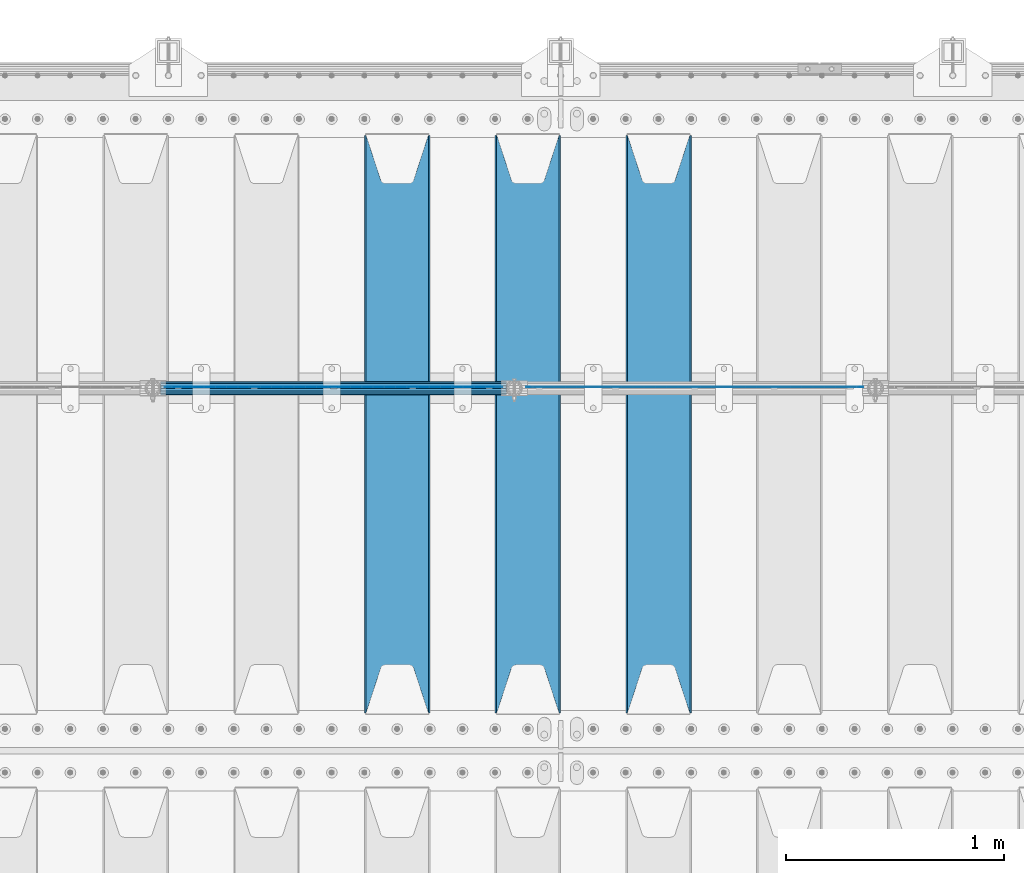
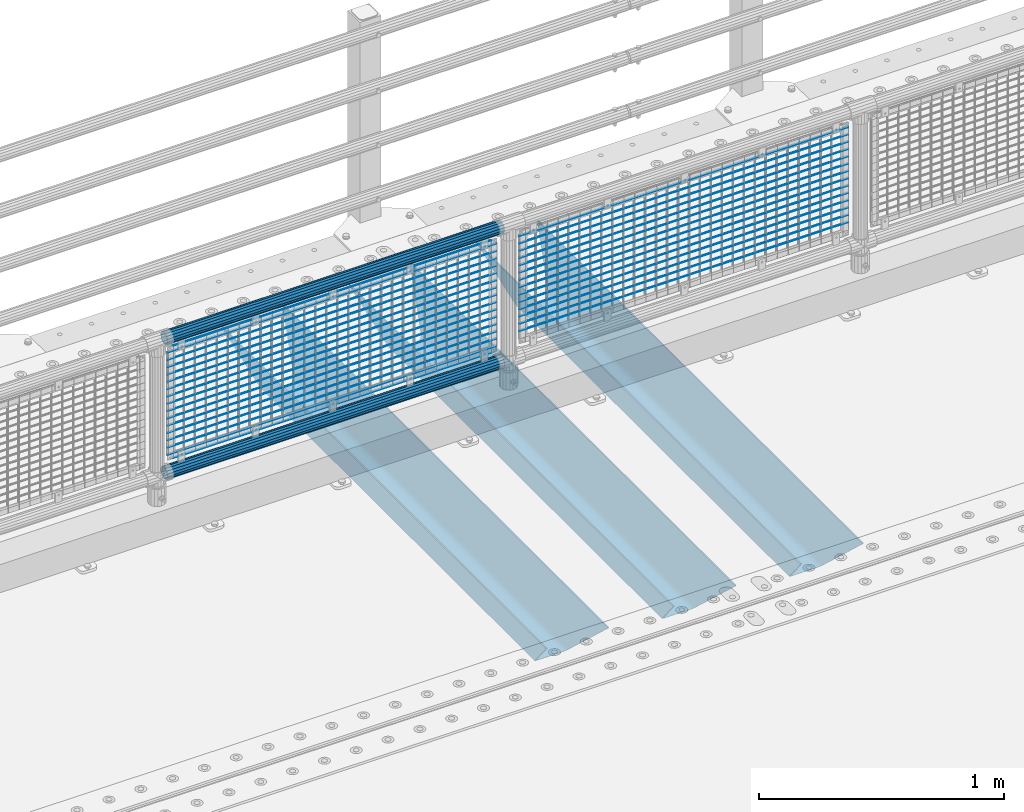
# One storey, part 90 of 193: 36 beams.
"""IFC2X3 building model written with IfcOpenShell, lengths in millimetres."""

from ifc_helpers import new_model, si_unit, frame, origin_with_axes, place, context, subcontext, project, spatial, faceted_brep, material, type_object, element, save


model = new_model("IFC2X3")

# Units and contexts
model_context = context("Model", 3, precision=1e-05, world=origin_with_axes())
body_context = subcontext(model_context, "Body", "Model", "MODEL_VIEW")
ifc_project = project(units=[si_unit("LENGTHUNIT", "METRE", prefix="MILLI"), si_unit("AREAUNIT", "SQUARE_METRE"), si_unit("VOLUMEUNIT", "CUBIC_METRE"), si_unit("MASSUNIT", "GRAM", prefix="KILO"), si_unit("TIMEUNIT", "SECOND"), si_unit("PLANEANGLEUNIT", "RADIAN"), si_unit("SOLIDANGLEUNIT", "STERADIAN"), si_unit("THERMODYNAMICTEMPERATUREUNIT", "DEGREE_CELSIUS"), si_unit("LUMINOUSINTENSITYUNIT", "LUMEN")], contexts=[model_context])

# Site, building, storey
site_placement = place(None, origin_with_axes())
site = spatial("IfcSite", under=ifc_project, at=site_placement, CompositionType="ELEMENT")
building_placement = place(site_placement, origin_with_axes())
building = spatial("IfcBuilding", under=site, at=building_placement, Name="Standard", CompositionType="ELEMENT")
storey_placement = place(building_placement, origin_with_axes())
storey = spatial("IfcBuildingStorey", under=building, at=storey_placement, Name="Undefined", CompositionType="ELEMENT", Elevation=0.0)

# Beams
ifc_material_1 = material(Name="STEEL/S355N")
beam_type_1 = type_object("IfcBeamType", PredefinedType="NOTDEFINED")
beam_1_placement = place(storey_placement, frame((-37850.0, 27175.0, -115.0), z_axis=(0.0, 0.0, 1.0), x_axis=(0.0, 1.0, 0.0)))
element("IfcBeam", 1, at=beam_1_placement, inside=storey, type_object=beam_type_1, material=ifc_material_1, context=body_context, shape_type="Brep", body=[
    faceted_brep([(0.0, 150.0, 115.0), (0.0, 143.689999999999, 115.0), (2650.00000000297, 143.689999999999, 115.0), (2650.00000000297, 150.0, 115.0), (2650.00000000297, 142.059565218398, 110.000000003094), (2650.00000000297, 148.3695652184, 110.000000003094), (2441.90079219209, -80.1103600731112, -98.0992078077845), (2437.7588105432, -77.5672621345584, -102.241189456673), (2434.06523489747, -74.4080125315522, -105.934765102404), (2430.9108609509, -70.710272125576, -109.089139048974), (2428.37322971128, -66.5649389910068, -111.626770288588), (2426.51472138055, -62.0739139532889, -113.485278619323), (2425.38102192092, -57.3475956567672, -114.618978078955), (2424.99999999988, -52.5021667386536, -115.0), (2424.99999999988, 52.5021667386536, -115.0), (2425.38102192092, 57.3475956567672, -114.618978078955), (2426.51472138055, 62.0739139532889, -113.485278619323), (2428.37322971128, 66.5649389910068, -111.626770288588), (2430.9108609509, 70.710272125576, -109.089139048974), (2434.06523489747, 74.4080125315522, -105.934765102404), (2437.7588105432, 77.5672621345584, -102.241189456673), (2441.90079219209, 80.1103600731112, -98.0992078077846), (2446.38936140512, 81.9747917625791, -93.6106385947584), (2448.2494850041, 76.2713538057251, -91.7505149957729), (2444.62967112263, 74.76777986261, -95.3703288772456), (2441.28936334127, 72.7168944282894, -98.710636658607), (2438.31067330439, 70.1691124903846, -101.689326695487), (2435.76682334748, 67.1870637758839, -104.233176652398), (2433.72034654134, 63.8440531834895, -106.279653458539), (2432.22154950042, 60.222258798236, -107.778450499454), (2431.30727574265, 56.4107117849089, -108.692724257221), (2430.99999999987, 52.5031078186876, -109.0), (2430.99999999987, -52.5031078186876, -109.0), (2431.30727574265, -56.4107117849089, -108.692724257221), (2432.22154950042, -60.222258798236, -107.778450499454), (2433.72034654134, -63.8440531834895, -106.279653458539), (2435.76682334748, -67.1870637758839, -104.233176652398), (2438.31067330439, -70.1691124903846, -101.689326695487), (2441.28936334127, -72.7168944282894, -98.7106366586071), (2444.62967112263, -74.76777986261, -95.3703288772457), (2448.2494850041, -76.2713538057251, -91.7505149957729), (2650.00000000297, -142.059565218398, 110.000000003094), (2650.00000000297, -148.3695652184, 110.000000003094), (2446.38936140512, -81.9747917625791, -93.6106385947584), (2650.00000000297, -143.689999999999, 115.0), (2650.00000000297, -150.0, 115.0), (0.0, -143.689999999999, 115.0), (0.0, -150.0, 115.0), (0.0, -148.369565218261, 110.000000002667), (203.610638597427, -81.9747917625791, -93.6106385947584), (208.099207810446, -80.1103600731112, -98.0992078077845), (212.241189459342, -77.5672621345584, -102.241189456673), (215.93476510507, -74.4080125315522, -105.934765102404), (219.089139051641, -70.710272125576, -109.089139048974), (221.626770291256, -66.5649389910068, -111.626770288588), (223.485278621989, -62.0739139532889, -113.485278619323), (224.618978081624, -57.3475956567672, -114.618978078955), (225.000000002663, -52.5021667386536, -115.0), (225.000000002663, 52.5021667386536, -115.0), (224.618978081624, 57.3475956567672, -114.618978078955), (223.485278621989, 62.0739139532889, -113.485278619323), (221.626770291256, 66.5649389910068, -111.626770288588), (219.089139051641, 70.710272125576, -109.089139048974), (215.93476510507, 74.4080125315522, -105.934765102404), (212.241189459342, 77.5672621345584, -102.241189456673), (208.099207810446, 80.1103600731112, -98.0992078077846), (203.610638597427, 81.9747917625791, -93.6106385947584), (0.0, 148.369565218261, 110.000000002667), (0.0, 142.05956521826, 110.000000002667), (201.750514998439, 76.2713538057251, -91.7505149957729), (205.370328879915, 74.76777986261, -95.3703288772456), (208.710636661275, 72.7168944282894, -98.710636658607), (211.689326698157, 70.1691124903846, -101.689326695487), (214.233176655063, 67.1870637758839, -104.233176652398), (216.279653461206, 63.8440531834895, -106.279653458539), (217.778450502123, 60.222258798236, -107.778450499454), (218.69272425989, 56.4107117849089, -108.692724257221), (219.00000000267, 52.5031078186876, -109.0), (219.00000000267, -52.5031078186876, -109.0), (218.69272425989, -56.4107117849089, -108.692724257221), (217.778450502123, -60.222258798236, -107.778450499454), (216.279653461206, -63.8440531834895, -106.279653458539), (214.233176655063, -67.1870637758839, -104.233176652398), (211.689326698157, -70.1691124903846, -101.689326695487), (208.710636661275, -72.7168944282894, -98.7106366586071), (205.370328879915, -74.76777986261, -95.3703288772457), (201.750514998439, -76.2713538057251, -91.7505149957729), (0.0, -142.05956521826, 110.000000002667)], [[[0, 1, 2, 3]], [[3, 2, 4, 5]], [[6, 7, 8, 9, 10, 11, 12, 13, 14, 15, 16, 17, 18, 19, 20, 21, 22, 5, 4, 23, 24, 25, 26, 27, 28, 29, 30, 31, 32, 33, 34, 35, 36, 37, 38, 39, 40, 41, 42, 43]], [[44, 45, 42, 41]], [[46, 47, 45, 44]], [[43, 42, 45, 47, 48, 49]], [[6, 43, 49, 50]], [[7, 6, 50, 51]], [[8, 7, 51, 52]], [[9, 8, 52, 53]], [[10, 9, 53, 54]], [[11, 10, 54, 55]], [[12, 11, 55, 56]], [[13, 12, 56, 57]], [[14, 13, 57, 58]], [[15, 14, 58, 59]], [[16, 15, 59, 60]], [[17, 16, 60, 61]], [[18, 17, 61, 62]], [[19, 18, 62, 63]], [[20, 19, 63, 64]], [[21, 20, 64, 65]], [[22, 21, 65, 66]], [[0, 3, 5, 22, 66, 67]], [[1, 0, 67, 68]], [[23, 4, 2, 1, 68, 69]], [[24, 23, 69, 70]], [[25, 24, 70, 71]], [[26, 25, 71, 72]], [[27, 26, 72, 73]], [[28, 27, 73, 74]], [[29, 28, 74, 75]], [[30, 29, 75, 76]], [[31, 30, 76, 77]], [[32, 31, 77, 78]], [[33, 32, 78, 79]], [[34, 33, 79, 80]], [[35, 34, 80, 81]], [[36, 35, 81, 82]], [[37, 36, 82, 83]], [[38, 37, 83, 84]], [[39, 38, 84, 85]], [[40, 39, 85, 86]], [[46, 44, 41, 40, 86, 87]], [[47, 46, 87, 48]], [[86, 85, 84, 83, 82, 81, 80, 79, 78, 77, 76, 75, 74, 73, 72, 71, 70, 69, 68, 67, 66, 65, 64, 63, 62, 61, 60, 59, 58, 57, 56, 55, 54, 53, 52, 51, 50, 49, 48, 87]]]),
])
beam_2_placement = place(storey_placement, frame((-38450.0, 27175.0, -115.0), z_axis=(0.0, 0.0, 1.0), x_axis=(0.0, 1.0, 0.0)))
element("IfcBeam", 2, at=beam_2_placement, inside=storey, type_object=beam_type_1, material=ifc_material_1, context=body_context, shape_type="Brep", body=[
    faceted_brep([(0.0, 150.0, 115.0), (0.0, 143.689999999999, 115.0), (2650.00000000297, 143.689999999999, 115.0), (2650.00000000297, 150.0, 115.0), (2650.00000000297, 142.059565218398, 110.000000003094), (2650.00000000297, 148.3695652184, 110.000000003094), (2441.90079219209, -80.1103600731112, -98.0992078077845), (2437.7588105432, -77.5672621345584, -102.241189456673), (2434.06523489747, -74.4080125315522, -105.934765102404), (2430.9108609509, -70.710272125576, -109.089139048974), (2428.37322971128, -66.5649389910068, -111.626770288588), (2426.51472138055, -62.0739139532889, -113.485278619323), (2425.38102192092, -57.3475956567672, -114.618978078955), (2424.99999999988, -52.5021667386536, -115.0), (2424.99999999988, 52.5021667386536, -115.0), (2425.38102192092, 57.3475956567672, -114.618978078955), (2426.51472138055, 62.0739139532889, -113.485278619323), (2428.37322971128, 66.5649389910068, -111.626770288588), (2430.9108609509, 70.710272125576, -109.089139048974), (2434.06523489747, 74.4080125315522, -105.934765102404), (2437.7588105432, 77.5672621345584, -102.241189456673), (2441.90079219209, 80.1103600731112, -98.0992078077846), (2446.38936140512, 81.9747917625791, -93.6106385947584), (2448.2494850041, 76.2713538057251, -91.7505149957729), (2444.62967112263, 74.76777986261, -95.3703288772456), (2441.28936334127, 72.7168944282894, -98.710636658607), (2438.31067330439, 70.1691124903846, -101.689326695487), (2435.76682334748, 67.1870637758839, -104.233176652398), (2433.72034654134, 63.8440531834895, -106.279653458539), (2432.22154950042, 60.222258798236, -107.778450499454), (2431.30727574265, 56.4107117849089, -108.692724257221), (2430.99999999987, 52.5031078186876, -109.0), (2430.99999999987, -52.5031078186876, -109.0), (2431.30727574265, -56.4107117849089, -108.692724257221), (2432.22154950042, -60.222258798236, -107.778450499454), (2433.72034654134, -63.8440531834895, -106.279653458539), (2435.76682334748, -67.1870637758839, -104.233176652398), (2438.31067330439, -70.1691124903846, -101.689326695487), (2441.28936334127, -72.7168944282894, -98.7106366586071), (2444.62967112263, -74.76777986261, -95.3703288772457), (2448.2494850041, -76.2713538057251, -91.7505149957729), (2650.00000000297, -142.059565218398, 110.000000003094), (2650.00000000297, -148.3695652184, 110.000000003094), (2446.38936140512, -81.9747917625791, -93.6106385947584), (2650.00000000297, -143.689999999999, 115.0), (2650.00000000297, -150.0, 115.0), (0.0, -143.689999999999, 115.0), (0.0, -150.0, 115.0), (0.0, -148.369565218261, 110.000000002667), (203.610638597427, -81.9747917625791, -93.6106385947584), (208.099207810446, -80.1103600731112, -98.0992078077845), (212.241189459342, -77.5672621345584, -102.241189456673), (215.93476510507, -74.4080125315522, -105.934765102404), (219.089139051641, -70.710272125576, -109.089139048974), (221.626770291256, -66.5649389910068, -111.626770288588), (223.485278621989, -62.0739139532889, -113.485278619323), (224.618978081624, -57.3475956567672, -114.618978078955), (225.000000002663, -52.5021667386536, -115.0), (225.000000002663, 52.5021667386536, -115.0), (224.618978081624, 57.3475956567672, -114.618978078955), (223.485278621989, 62.0739139532889, -113.485278619323), (221.626770291256, 66.5649389910068, -111.626770288588), (219.089139051641, 70.710272125576, -109.089139048974), (215.93476510507, 74.4080125315522, -105.934765102404), (212.241189459342, 77.5672621345584, -102.241189456673), (208.099207810446, 80.1103600731112, -98.0992078077846), (203.610638597427, 81.9747917625791, -93.6106385947584), (0.0, 148.369565218261, 110.000000002667), (0.0, 142.05956521826, 110.000000002667), (201.750514998439, 76.2713538057251, -91.7505149957729), (205.370328879915, 74.76777986261, -95.3703288772456), (208.710636661275, 72.7168944282894, -98.710636658607), (211.689326698157, 70.1691124903846, -101.689326695487), (214.233176655063, 67.1870637758839, -104.233176652398), (216.279653461206, 63.8440531834895, -106.279653458539), (217.778450502123, 60.222258798236, -107.778450499454), (218.69272425989, 56.4107117849089, -108.692724257221), (219.00000000267, 52.5031078186876, -109.0), (219.00000000267, -52.5031078186876, -109.0), (218.69272425989, -56.4107117849089, -108.692724257221), (217.778450502123, -60.222258798236, -107.778450499454), (216.279653461206, -63.8440531834895, -106.279653458539), (214.233176655063, -67.1870637758839, -104.233176652398), (211.689326698157, -70.1691124903846, -101.689326695487), (208.710636661275, -72.7168944282894, -98.7106366586071), (205.370328879915, -74.76777986261, -95.3703288772457), (201.750514998439, -76.2713538057251, -91.7505149957729), (0.0, -142.05956521826, 110.000000002667)], [[[0, 1, 2, 3]], [[3, 2, 4, 5]], [[6, 7, 8, 9, 10, 11, 12, 13, 14, 15, 16, 17, 18, 19, 20, 21, 22, 5, 4, 23, 24, 25, 26, 27, 28, 29, 30, 31, 32, 33, 34, 35, 36, 37, 38, 39, 40, 41, 42, 43]], [[44, 45, 42, 41]], [[46, 47, 45, 44]], [[43, 42, 45, 47, 48, 49]], [[6, 43, 49, 50]], [[7, 6, 50, 51]], [[8, 7, 51, 52]], [[9, 8, 52, 53]], [[10, 9, 53, 54]], [[11, 10, 54, 55]], [[12, 11, 55, 56]], [[13, 12, 56, 57]], [[14, 13, 57, 58]], [[15, 14, 58, 59]], [[16, 15, 59, 60]], [[17, 16, 60, 61]], [[18, 17, 61, 62]], [[19, 18, 62, 63]], [[20, 19, 63, 64]], [[21, 20, 64, 65]], [[22, 21, 65, 66]], [[0, 3, 5, 22, 66, 67]], [[1, 0, 67, 68]], [[23, 4, 2, 1, 68, 69]], [[24, 23, 69, 70]], [[25, 24, 70, 71]], [[26, 25, 71, 72]], [[27, 26, 72, 73]], [[28, 27, 73, 74]], [[29, 28, 74, 75]], [[30, 29, 75, 76]], [[31, 30, 76, 77]], [[32, 31, 77, 78]], [[33, 32, 78, 79]], [[34, 33, 79, 80]], [[35, 34, 80, 81]], [[36, 35, 81, 82]], [[37, 36, 82, 83]], [[38, 37, 83, 84]], [[39, 38, 84, 85]], [[40, 39, 85, 86]], [[46, 44, 41, 40, 86, 87]], [[47, 46, 87, 48]], [[86, 85, 84, 83, 82, 81, 80, 79, 78, 77, 76, 75, 74, 73, 72, 71, 70, 69, 68, 67, 66, 65, 64, 63, 62, 61, 60, 59, 58, 57, 56, 55, 54, 53, 52, 51, 50, 49, 48, 87]]]),
])
beam_3_placement = place(storey_placement, frame((-39050.0, 27175.0, -115.0), z_axis=(0.0, 0.0, 1.0), x_axis=(0.0, 1.0, 0.0)))
element("IfcBeam", 3, at=beam_3_placement, inside=storey, type_object=beam_type_1, material=ifc_material_1, context=body_context, shape_type="Brep", body=[
    faceted_brep([(0.0, 150.0, 115.0), (0.0, 143.689999999999, 115.0), (2650.00000000297, 143.689999999999, 115.0), (2650.00000000297, 150.0, 115.0), (2650.00000000297, 142.059565218398, 110.000000003094), (2650.00000000297, 148.3695652184, 110.000000003094), (2441.90079219209, -80.1103600731112, -98.0992078077845), (2437.7588105432, -77.5672621345584, -102.241189456673), (2434.06523489747, -74.4080125315522, -105.934765102404), (2430.9108609509, -70.710272125576, -109.089139048974), (2428.37322971128, -66.5649389910068, -111.626770288588), (2426.51472138055, -62.0739139532889, -113.485278619323), (2425.38102192092, -57.3475956567672, -114.618978078955), (2424.99999999988, -52.5021667386536, -115.0), (2424.99999999988, 52.5021667386536, -115.0), (2425.38102192092, 57.3475956567672, -114.618978078955), (2426.51472138055, 62.0739139532889, -113.485278619323), (2428.37322971128, 66.5649389910068, -111.626770288588), (2430.9108609509, 70.710272125576, -109.089139048974), (2434.06523489747, 74.4080125315522, -105.934765102404), (2437.7588105432, 77.5672621345584, -102.241189456673), (2441.90079219209, 80.1103600731112, -98.0992078077846), (2446.38936140512, 81.9747917625791, -93.6106385947584), (2448.2494850041, 76.2713538057251, -91.7505149957729), (2444.62967112263, 74.76777986261, -95.3703288772456), (2441.28936334127, 72.7168944282894, -98.710636658607), (2438.31067330439, 70.1691124903846, -101.689326695487), (2435.76682334748, 67.1870637758839, -104.233176652398), (2433.72034654134, 63.8440531834895, -106.279653458539), (2432.22154950042, 60.222258798236, -107.778450499454), (2431.30727574265, 56.4107117849089, -108.692724257221), (2430.99999999987, 52.5031078186876, -109.0), (2430.99999999987, -52.5031078186876, -109.0), (2431.30727574265, -56.4107117849089, -108.692724257221), (2432.22154950042, -60.222258798236, -107.778450499454), (2433.72034654134, -63.8440531834895, -106.279653458539), (2435.76682334748, -67.1870637758839, -104.233176652398), (2438.31067330439, -70.1691124903846, -101.689326695487), (2441.28936334127, -72.7168944282894, -98.7106366586071), (2444.62967112263, -74.76777986261, -95.3703288772457), (2448.2494850041, -76.2713538057251, -91.7505149957729), (2650.00000000297, -142.059565218398, 110.000000003094), (2650.00000000297, -148.3695652184, 110.000000003094), (2446.38936140512, -81.9747917625791, -93.6106385947584), (2650.00000000297, -143.689999999999, 115.0), (2650.00000000297, -150.0, 115.0), (0.0, -143.689999999999, 115.0), (0.0, -150.0, 115.0), (0.0, -148.369565218261, 110.000000002667), (203.610638597427, -81.9747917625791, -93.6106385947584), (208.099207810446, -80.1103600731112, -98.0992078077845), (212.241189459342, -77.5672621345584, -102.241189456673), (215.93476510507, -74.4080125315522, -105.934765102404), (219.089139051641, -70.710272125576, -109.089139048974), (221.626770291256, -66.5649389910068, -111.626770288588), (223.485278621989, -62.0739139532889, -113.485278619323), (224.618978081624, -57.3475956567672, -114.618978078955), (225.000000002663, -52.5021667386536, -115.0), (225.000000002663, 52.5021667386536, -115.0), (224.618978081624, 57.3475956567672, -114.618978078955), (223.485278621989, 62.0739139532889, -113.485278619323), (221.626770291256, 66.5649389910068, -111.626770288588), (219.089139051641, 70.710272125576, -109.089139048974), (215.93476510507, 74.4080125315522, -105.934765102404), (212.241189459342, 77.5672621345584, -102.241189456673), (208.099207810446, 80.1103600731112, -98.0992078077846), (203.610638597427, 81.9747917625791, -93.6106385947584), (0.0, 148.369565218261, 110.000000002667), (0.0, 142.05956521826, 110.000000002667), (201.750514998439, 76.2713538057251, -91.7505149957729), (205.370328879915, 74.76777986261, -95.3703288772456), (208.710636661275, 72.7168944282894, -98.710636658607), (211.689326698157, 70.1691124903846, -101.689326695487), (214.233176655063, 67.1870637758839, -104.233176652398), (216.279653461206, 63.8440531834895, -106.279653458539), (217.778450502123, 60.222258798236, -107.778450499454), (218.69272425989, 56.4107117849089, -108.692724257221), (219.00000000267, 52.5031078186876, -109.0), (219.00000000267, -52.5031078186876, -109.0), (218.69272425989, -56.4107117849089, -108.692724257221), (217.778450502123, -60.222258798236, -107.778450499454), (216.279653461206, -63.8440531834895, -106.279653458539), (214.233176655063, -67.1870637758839, -104.233176652398), (211.689326698157, -70.1691124903846, -101.689326695487), (208.710636661275, -72.7168944282894, -98.7106366586071), (205.370328879915, -74.76777986261, -95.3703288772457), (201.750514998439, -76.2713538057251, -91.7505149957729), (0.0, -142.05956521826, 110.000000002667)], [[[0, 1, 2, 3]], [[3, 2, 4, 5]], [[6, 7, 8, 9, 10, 11, 12, 13, 14, 15, 16, 17, 18, 19, 20, 21, 22, 5, 4, 23, 24, 25, 26, 27, 28, 29, 30, 31, 32, 33, 34, 35, 36, 37, 38, 39, 40, 41, 42, 43]], [[44, 45, 42, 41]], [[46, 47, 45, 44]], [[43, 42, 45, 47, 48, 49]], [[6, 43, 49, 50]], [[7, 6, 50, 51]], [[8, 7, 51, 52]], [[9, 8, 52, 53]], [[10, 9, 53, 54]], [[11, 10, 54, 55]], [[12, 11, 55, 56]], [[13, 12, 56, 57]], [[14, 13, 57, 58]], [[15, 14, 58, 59]], [[16, 15, 59, 60]], [[17, 16, 60, 61]], [[18, 17, 61, 62]], [[19, 18, 62, 63]], [[20, 19, 63, 64]], [[21, 20, 64, 65]], [[22, 21, 65, 66]], [[0, 3, 5, 22, 66, 67]], [[1, 0, 67, 68]], [[23, 4, 2, 1, 68, 69]], [[24, 23, 69, 70]], [[25, 24, 70, 71]], [[26, 25, 71, 72]], [[27, 26, 72, 73]], [[28, 27, 73, 74]], [[29, 28, 74, 75]], [[30, 29, 75, 76]], [[31, 30, 76, 77]], [[32, 31, 77, 78]], [[33, 32, 78, 79]], [[34, 33, 79, 80]], [[35, 34, 80, 81]], [[36, 35, 81, 82]], [[37, 36, 82, 83]], [[38, 37, 83, 84]], [[39, 38, 84, 85]], [[40, 39, 85, 86]], [[46, 44, 41, 40, 86, 87]], [[47, 46, 87, 48]], [[86, 85, 84, 83, 82, 81, 80, 79, 78, 77, 76, 75, 74, 73, 72, 71, 70, 69, 68, 67, 66, 65, 64, 63, 62, 61, 60, 59, 58, 57, 56, 55, 54, 53, 52, 51, 50, 49, 48, 87]]]),
])
ifc_material_2 = material(Name="Misc_Undefined")
beam_type_2 = type_object("IfcBeamType", Name="D3", PredefinedType="NOTDEFINED")
for number, where, z_axis, x_axis in (
    (4, (-38458.0, 28670.5, 851.597), (0.0, 0.0, 1.0), (1.0, 0.0, 0.0)),
    (5, (-38458.0, 28670.5, 669.452), (0.0, 0.0, 1.0), (1.0, 0.0, 0.0)),
    (6, (-38458.0, 28670.5, 523.736), (0.0, 0.0, 1.0), (1.0, 0.0, 0.0)),
    (7, (-38458.0, 28670.5, 487.307), (0.0, 0.0, 1.0), (1.0, 0.0, 0.0)),
    (8, (-38458.0, 28670.5, 705.881), (0.0, 0.0, 1.0), (1.0, 0.0, 0.0)),
    (9, (-38458.0, 28670.5, 596.594), (0.0, 0.0, 1.0), (1.0, 0.0, 0.0)),
    (10, (-38458.0, 28670.5, 450.878), (0.0, 0.0, 1.0), (1.0, 0.0, 0.0)),
    (11, (-38458.0, 28670.5, 815.168), (0.0, 0.0, 1.0), (1.0, 0.0, 0.0)),
    (12, (-38458.0, 28670.5, 888.026), (0.0, 0.0, 1.0), (1.0, 0.0, 0.0)),
    (13, (-38458.0, 28670.5, 778.739), (0.0, 0.0, 1.0), (1.0, 0.0, 0.0)),
    (14, (-38458.0, 28670.5, 742.31), (0.0, 0.0, 1.0), (1.0, 0.0, 0.0)),
    (15, (-38458.0, 28670.5, 633.023), (0.0, 0.0, 1.0), (1.0, 0.0, 0.0)),
    (16, (-38458.0, 28670.5, 560.165), (0.0, 0.0, 1.0), (1.0, 0.0, 0.0)),
    (17, (-38458.0, 28670.5, 414.449), (0.0, 0.0, 1.0), (1.0, 0.0, 0.0)),
    (18, (-40116.0, 28670.5, 851.597), (0.0, 0.0, 1.0), (1.0, 0.0, 0.0)),
    (19, (-40116.0, 28670.5, 669.452), (0.0, 0.0, 1.0), (1.0, 0.0, 0.0)),
    (20, (-40116.0, 28670.5, 523.736), (0.0, 0.0, 1.0), (1.0, 0.0, 0.0)),
    (21, (-40116.0, 28670.5, 487.307), (0.0, 0.0, 1.0), (1.0, 0.0, 0.0)),
    (22, (-40116.0, 28670.5, 705.881), (0.0, 0.0, 1.0), (1.0, 0.0, 0.0)),
    (23, (-40116.0, 28670.5, 596.594), (0.0, 0.0, 1.0), (1.0, 0.0, 0.0)),
    (24, (-40116.0, 28670.5, 450.878), (0.0, 0.0, 1.0), (1.0, 0.0, 0.0)),
    (25, (-40116.0, 28670.5, 815.168), (0.0, 0.0, 1.0), (1.0, 0.0, 0.0)),
    (26, (-40116.0, 28670.5, 888.026), (0.0, 0.0, 1.0), (1.0, 0.0, 0.0)),
    (27, (-40116.0, 28670.5, 778.739), (0.0, 0.0, 1.0), (1.0, 0.0, 0.0)),
    (28, (-40116.0, 28670.5, 742.31), (0.0, 0.0, 1.0), (1.0, 0.0, 0.0)),
    (29, (-40116.0, 28670.5, 633.023), (0.0, 0.0, 1.0), (1.0, 0.0, 0.0)),
    (30, (-40116.0, 28670.5, 560.165), (0.0, 0.0, 1.0), (1.0, 0.0, 0.0)),
    (31, (-40116.0, 28670.5, 414.449), (0.0, 0.0, 1.0), (1.0, 0.0, 0.0)),
):
    element("IfcBeam", number, at=place(storey_placement, frame(where, z_axis=z_axis, x_axis=x_axis)), inside=storey, type_object=beam_type_2, material=ifc_material_2, ObjectType="D3", context=body_context, shape_type="Brep", body=[
        faceted_brep([(0.0, -1.49999999999636, 3.63797880709171e-12), (0.0, -0.75, -1.29903810567669), (1548.0, -0.75, -1.29903810567669), (1548.0, -1.5, 0.0), (0.0, 0.75, -1.29903810567669), (1548.0, 0.75, -1.29903810567669), (0.0, 1.50000000000364, 7.27595761418343e-12), (1548.0, 1.5, 0.0), (0.0, 0.75, 1.29903810567669), (1548.0, 0.75, 1.29903810567669), (0.0, -0.75, 1.29903810567669), (1548.0, -0.75, 1.29903810567669)], [[[0, 1, 2, 3]], [[1, 4, 5, 2]], [[4, 6, 7, 5]], [[6, 8, 9, 7]], [[8, 10, 11, 9]], [[10, 0, 3, 11]], [[5, 7, 9, 11, 3, 2]], [[10, 8, 6, 4, 1, 0]]]),
    ])
beam_4_placement = place(storey_placement, frame((-40091.0, 28670.5, 353.02), z_axis=(0.0, 0.0, 1.0), x_axis=(1.0, 0.0, 0.0)))
element("IfcBeam", 32, at=beam_4_placement, inside=storey, type_object=beam_type_2, material=ifc_material_2, ObjectType="D3", context=body_context, shape_type="Brep", body=[
    faceted_brep([(0.0, -1.49999999999636, 3.63797880709171e-12), (0.0, -0.75, -1.29903810567669), (1498.0, -0.75, -1.29903810567669), (1498.0, -1.5, 0.0), (0.0, 0.75, -1.29903810567669), (1498.0, 0.75, -1.29903810567663), (0.0, 1.50000000000364, 7.27595761418343e-12), (1498.0, 1.5, 0.0), (0.0, 0.75, 1.29903810567669), (1498.0, 0.75, 1.29903810567669), (0.0, -0.75, 1.29903810567669), (1498.0, -0.75, 1.29903810567669)], [[[0, 1, 2, 3]], [[1, 4, 5, 2]], [[4, 6, 7, 5]], [[6, 8, 9, 7]], [[8, 10, 11, 9]], [[10, 0, 3, 11]], [[5, 7, 9, 11, 3, 2]], [[10, 8, 6, 4, 1, 0]]]),
])
beam_5_placement = place(storey_placement, frame((-40116.0, 28670.5, 378.02), z_axis=(0.0, 0.0, 1.0), x_axis=(1.0, 0.0, 0.0)))
element("IfcBeam", 33, at=beam_5_placement, inside=storey, type_object=beam_type_2, material=ifc_material_2, ObjectType="D3", context=body_context, shape_type="Brep", body=[
    faceted_brep([(0.0, -1.49999999999636, 3.63797880709171e-12), (0.0, -0.75, -1.29903810567669), (1548.0, -0.75, -1.29903810567669), (1548.0, -1.5, 0.0), (0.0, 0.75, -1.29903810567669), (1548.0, 0.75, -1.29903810567669), (0.0, 1.50000000000364, 7.27595761418343e-12), (1548.0, 1.5, 0.0), (0.0, 0.75, 1.29903810567669), (1548.0, 0.75, 1.29903810567669), (0.0, -0.75, 1.29903810567669), (1548.0, -0.75, 1.29903810567669)], [[[0, 1, 2, 3]], [[1, 4, 5, 2]], [[4, 6, 7, 5]], [[6, 8, 9, 7]], [[8, 10, 11, 9]], [[10, 0, 3, 11]], [[5, 7, 9, 11, 3, 2]], [[10, 8, 6, 4, 1, 0]]]),
])
beam_6_placement = place(storey_placement, frame((-40091.0, 28670.5, 913.02), z_axis=(0.0, 0.0, 1.0), x_axis=(1.0, 0.0, 0.0)))
element("IfcBeam", 34, at=beam_6_placement, inside=storey, type_object=beam_type_2, material=ifc_material_2, ObjectType="D3", context=body_context, shape_type="Brep", body=[
    faceted_brep([(0.0, -1.49999999999636, 3.63797880709171e-12), (0.0, -0.75, -1.29903810567669), (1498.0, -0.75, -1.29903810567669), (1498.0, -1.5, 0.0), (0.0, 0.75, -1.29903810567669), (1498.0, 0.75, -1.29903810567663), (0.0, 1.50000000000364, 7.27595761418343e-12), (1498.0, 1.5, 0.0), (0.0, 0.75, 1.29903810567669), (1498.0, 0.75, 1.29903810567669), (0.0, -0.75, 1.29903810567669), (1498.0, -0.75, 1.29903810567669)], [[[0, 1, 2, 3]], [[1, 4, 5, 2]], [[4, 6, 7, 5]], [[6, 8, 9, 7]], [[8, 10, 11, 9]], [[10, 0, 3, 11]], [[5, 7, 9, 11, 3, 2]], [[10, 8, 6, 4, 1, 0]]]),
])
ifc_material_3 = material()
beam_type_3 = type_object("IfcBeamType", PredefinedType="NOTDEFINED")
beam_7_placement = place(storey_placement, frame((-40136.15, 28664.5, 969.85), z_axis=(0.0, 0.0, 1.0), x_axis=(1.0, 0.0, 0.0)))
element("IfcBeam", 35, at=beam_7_placement, inside=storey, type_object=beam_type_3, material=ifc_material_3, context=body_context, shape_type="Brep", body=[
    faceted_brep([(0.0, -25.3499999999985, 0.0), (0.0, -23.4203461491597, 9.70102501045403), (1588.0, -23.4203461491597, 9.70102501045506), (1588.0, -25.3499999999985, 0.0), (0.0, -17.9251569030785, 17.9251569030785), (1588.0, -17.9251569030785, 17.925156903079), (0.0, -9.70102501045403, 23.4203461491597), (1588.0, -9.70102501045403, 23.4203461491611), (0.0, 0.0, 25.3499999999985), (1588.0, 0.0, 25.35), (0.0, 9.70102501045403, 23.4203461491597), (1588.0, 9.70102501045403, 23.4203461491611), (0.0, 17.9251569030785, 17.9251569030785), (1588.0, 17.9251569030785, 17.925156903079), (0.0, 23.4203461491597, 9.70102501045403), (1588.0, 23.4203461491597, 9.70102501045506), (0.0, 25.3499999999985, 0.0), (1588.0, 25.3499999999985, 0.0), (0.0, 23.4203461491597, -9.70102501045403), (1588.0, 23.4203461491597, -9.70102501045506), (0.0, 17.9251569030785, -17.9251569030785), (1588.0, 17.9251569030785, -17.925156903079), (0.0, 9.70102501045403, -23.4203461491597), (1588.0, 9.70102501045403, -23.4203461491611), (0.0, 0.0, -25.3499999999985), (1588.0, 0.0, -25.35), (0.0, -9.70102501045403, -23.4203461491597), (1588.0, -9.70102501045403, -23.4203461491611), (0.0, -17.9251569030785, -17.9251569030785), (1588.0, -17.9251569030785, -17.925156903079), (0.0, -23.4203461491597, -9.70102501045403), (1588.0, -23.4203461491597, -9.70102501045506), (0.0, -30.1500000000015, 0.0), (0.0, -27.8549679052157, -11.5379054858058), (1588.0, -27.8549679052157, -11.5379054858075), (1588.0, -30.1500000000015, 0.0), (0.0, -21.3192694527752, -21.3192694527752), (1588.0, -21.3192694527752, -21.3192694527744), (0.0, -11.5379054858058, -27.8549679052157), (1588.0, -11.5379054858058, -27.8549679052153), (0.0, 0.0, -30.1500000000015), (1588.0, 0.0, -30.15), (0.0, 11.5379054858058, -27.8549679052157), (1588.0, 11.5379054858058, -27.8549679052153), (0.0, 21.3192694527752, -21.3192694527752), (1588.0, 21.3192694527752, -21.3192694527744), (0.0, 27.8549679052157, -11.5379054858058), (1588.0, 27.8549679052157, -11.5379054858074), (0.0, 30.1500000000015, 0.0), (1588.0, 30.1500000000015, 0.0), (0.0, 27.8549679052157, 11.5379054858058), (1588.0, 27.8549679052157, 11.5379054858074), (0.0, 21.3192694527752, 21.3192694527752), (1588.0, 21.3192694527752, 21.3192694527744), (0.0, 11.5379054858058, 27.8549679052157), (1588.0, 11.5379054858058, 27.8549679052153), (0.0, 0.0, 30.1500000000015), (1588.0, 0.0, 30.15), (0.0, -11.5379054858058, 27.8549679052157), (1588.0, -11.5379054858058, 27.8549679052153), (0.0, -21.3192694527752, 21.3192694527752), (1588.0, -21.3192694527752, 21.3192694527744), (0.0, -27.8549679052157, 11.5379054858058), (1588.0, -27.8549679052157, 11.5379054858074)], [[[0, 1, 2, 3]], [[1, 4, 5, 2]], [[4, 6, 7, 5]], [[6, 8, 9, 7]], [[8, 10, 11, 9]], [[10, 12, 13, 11]], [[12, 14, 15, 13]], [[14, 16, 17, 15]], [[16, 18, 19, 17]], [[18, 20, 21, 19]], [[20, 22, 23, 21]], [[22, 24, 25, 23]], [[24, 26, 27, 25]], [[26, 28, 29, 27]], [[28, 30, 31, 29]], [[30, 0, 3, 31]], [[32, 33, 34, 35]], [[33, 36, 37, 34]], [[36, 38, 39, 37]], [[38, 40, 41, 39]], [[40, 42, 43, 41]], [[42, 44, 45, 43]], [[44, 46, 47, 45]], [[46, 48, 49, 47]], [[48, 50, 51, 49]], [[50, 52, 53, 51]], [[52, 54, 55, 53]], [[54, 56, 57, 55]], [[56, 58, 59, 57]], [[58, 60, 61, 59]], [[60, 62, 63, 61]], [[62, 32, 35, 63]], [[37, 39, 41, 43, 45, 47, 49, 51, 53, 55, 57, 59, 61, 63, 35, 34], [5, 7, 9, 11, 13, 15, 17, 19, 21, 23, 25, 27, 29, 31, 3, 2]], [[62, 60, 58, 56, 54, 52, 50, 48, 46, 44, 42, 40, 38, 36, 33, 32], [30, 28, 26, 24, 22, 20, 18, 16, 14, 12, 10, 8, 6, 4, 1, 0]]]),
])
beam_8_placement = place(storey_placement, frame((-40136.15, 28664.5, 298.170000000001), z_axis=(0.0, 0.0, 1.0), x_axis=(1.0, 0.0, 0.0)))
element("IfcBeam", 36, at=beam_8_placement, inside=storey, type_object=beam_type_3, material=ifc_material_3, context=body_context, shape_type="Brep", body=[
    faceted_brep([(0.0, -25.3499999999985, 0.0), (0.0, -23.4203461491597, 9.70102501045403), (1588.0, -23.4203461491597, 9.70102501045506), (1588.0, -25.3499999999985, 0.0), (0.0, -17.9251569030785, 17.9251569030785), (1588.0, -17.9251569030785, 17.925156903079), (0.0, -9.70102501045403, 23.4203461491597), (1588.0, -9.70102501045403, 23.4203461491611), (0.0, 0.0, 25.3499999999985), (1588.0, 0.0, 25.35), (0.0, 9.70102501045403, 23.4203461491597), (1588.0, 9.70102501045403, 23.4203461491611), (0.0, 17.9251569030785, 17.9251569030785), (1588.0, 17.9251569030785, 17.925156903079), (0.0, 23.4203461491597, 9.70102501045403), (1588.0, 23.4203461491597, 9.70102501045506), (0.0, 25.3499999999985, 0.0), (1588.0, 25.3499999999985, 0.0), (0.0, 23.4203461491597, -9.70102501045403), (1588.0, 23.4203461491597, -9.70102501045506), (0.0, 17.9251569030785, -17.9251569030785), (1588.0, 17.9251569030785, -17.925156903079), (0.0, 9.70102501045403, -23.4203461491597), (1588.0, 9.70102501045403, -23.4203461491611), (0.0, 0.0, -25.3499999999985), (1588.0, 0.0, -25.35), (0.0, -9.70102501045403, -23.4203461491597), (1588.0, -9.70102501045403, -23.4203461491611), (0.0, -17.9251569030785, -17.9251569030785), (1588.0, -17.9251569030785, -17.925156903079), (0.0, -23.4203461491597, -9.70102501045403), (1588.0, -23.4203461491597, -9.70102501045506), (0.0, -30.1500000000015, 0.0), (0.0, -27.8549679052157, -11.5379054858058), (1588.0, -27.8549679052157, -11.5379054858075), (1588.0, -30.1500000000015, 0.0), (0.0, -21.3192694527752, -21.3192694527752), (1588.0, -21.3192694527752, -21.3192694527744), (0.0, -11.5379054858058, -27.8549679052157), (1588.0, -11.5379054858058, -27.8549679052153), (0.0, 0.0, -30.1500000000015), (1588.0, 0.0, -30.15), (0.0, 11.5379054858058, -27.8549679052157), (1588.0, 11.5379054858058, -27.8549679052153), (0.0, 21.3192694527752, -21.3192694527752), (1588.0, 21.3192694527752, -21.3192694527744), (0.0, 27.8549679052157, -11.5379054858058), (1588.0, 27.8549679052157, -11.5379054858074), (0.0, 30.1500000000015, 0.0), (1588.0, 30.1500000000015, 0.0), (0.0, 27.8549679052157, 11.5379054858058), (1588.0, 27.8549679052157, 11.5379054858074), (0.0, 21.3192694527752, 21.3192694527752), (1588.0, 21.3192694527752, 21.3192694527744), (0.0, 11.5379054858058, 27.8549679052157), (1588.0, 11.5379054858058, 27.8549679052153), (0.0, 0.0, 30.1500000000015), (1588.0, 0.0, 30.15), (0.0, -11.5379054858058, 27.8549679052157), (1588.0, -11.5379054858058, 27.8549679052153), (0.0, -21.3192694527752, 21.3192694527752), (1588.0, -21.3192694527752, 21.3192694527744), (0.0, -27.8549679052157, 11.5379054858058), (1588.0, -27.8549679052157, 11.5379054858074)], [[[0, 1, 2, 3]], [[1, 4, 5, 2]], [[4, 6, 7, 5]], [[6, 8, 9, 7]], [[8, 10, 11, 9]], [[10, 12, 13, 11]], [[12, 14, 15, 13]], [[14, 16, 17, 15]], [[16, 18, 19, 17]], [[18, 20, 21, 19]], [[20, 22, 23, 21]], [[22, 24, 25, 23]], [[24, 26, 27, 25]], [[26, 28, 29, 27]], [[28, 30, 31, 29]], [[30, 0, 3, 31]], [[32, 33, 34, 35]], [[33, 36, 37, 34]], [[36, 38, 39, 37]], [[38, 40, 41, 39]], [[40, 42, 43, 41]], [[42, 44, 45, 43]], [[44, 46, 47, 45]], [[46, 48, 49, 47]], [[48, 50, 51, 49]], [[50, 52, 53, 51]], [[52, 54, 55, 53]], [[54, 56, 57, 55]], [[56, 58, 59, 57]], [[58, 60, 61, 59]], [[60, 62, 63, 61]], [[62, 32, 35, 63]], [[37, 39, 41, 43, 45, 47, 49, 51, 53, 55, 57, 59, 61, 63, 35, 34], [5, 7, 9, 11, 13, 15, 17, 19, 21, 23, 25, 27, 29, 31, 3, 2]], [[62, 60, 58, 56, 54, 52, 50, 48, 46, 44, 42, 40, 38, 36, 33, 32], [30, 28, 26, 24, 22, 20, 18, 16, 14, 12, 10, 8, 6, 4, 1, 0]]]),
])

save(model, "model.ifc")
